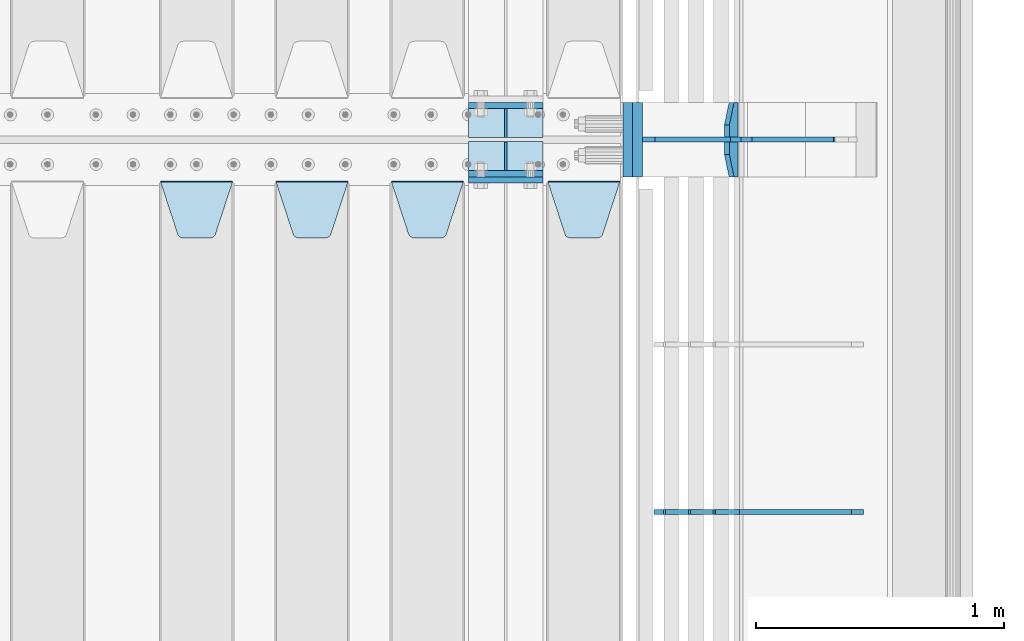
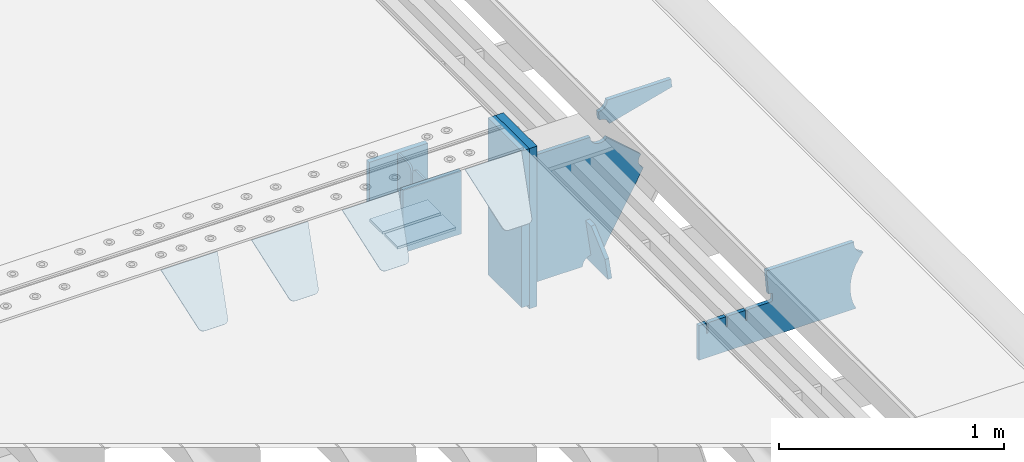
# One storey, part 225 of 247: 17 plates.
"""IFC2X3 building model written with IfcOpenShell, lengths in millimetres."""

from ifc_helpers import new_model, si_unit, frame, origin_with_axes, place, context, subcontext, project, spatial, faceted_brep, material, type_object, element, save


model = new_model("IFC2X3")

# Units and contexts
model_context = context("Model", 3, precision=1e-05, world=origin_with_axes())
body_context = subcontext(model_context, "Body", "Model", "MODEL_VIEW")
ifc_project = project(units=[si_unit("LENGTHUNIT", "METRE", prefix="MILLI"), si_unit("AREAUNIT", "SQUARE_METRE"), si_unit("VOLUMEUNIT", "CUBIC_METRE"), si_unit("MASSUNIT", "GRAM", prefix="KILO"), si_unit("TIMEUNIT", "SECOND"), si_unit("PLANEANGLEUNIT", "RADIAN"), si_unit("SOLIDANGLEUNIT", "STERADIAN"), si_unit("THERMODYNAMICTEMPERATUREUNIT", "DEGREE_CELSIUS"), si_unit("LUMINOUSINTENSITYUNIT", "LUMEN")], contexts=[model_context])

# Site, building, storey
site_placement = place(None, origin_with_axes())
site = spatial("IfcSite", under=ifc_project, at=site_placement, CompositionType="ELEMENT")
building_placement = place(site_placement, origin_with_axes())
building = spatial("IfcBuilding", under=site, at=building_placement, Name="Standard", CompositionType="ELEMENT")
storey_placement = place(building_placement, origin_with_axes())
storey = spatial("IfcBuildingStorey", under=building, at=storey_placement, Name="Undefined", CompositionType="ELEMENT", Elevation=0.0)

# Plates
ifc_material_1 = material(Name="STEEL/S355N")
plate_type_1 = type_object("IfcPlateType", PredefinedType="NOTDEFINED")
for number, where, z_axis, x_axis in (
    (1, (16195.0, 3137.49999999999, -339.999999999993), (0.0, 0.0, 1.0), (1.0, 0.0, 0.0)),
    (2, (16195.0, 2862.49999999999, -339.999999999993), (0.0, 0.0, 1.0), (1.0, 0.0, 0.0)),
):
    element("IfcPlate", number, at=place(storey_placement, frame(where, z_axis=z_axis, x_axis=x_axis)), inside=storey, type_object=plate_type_1, material=ifc_material_1, context=body_context, shape_type="Brep", body=[
        faceted_brep([(0.0, -12.5, 0.0), (0.0, -12.5, 310.0), (0.0, 12.5, 310.0), (0.0, 12.5, 0.0), (300.0, -12.5, 310.0), (300.0, 12.5, 310.0), (300.0, -12.5, 0.0), (300.0, 12.5, 0.0)], [[[0, 1, 2, 3]], [[1, 4, 5, 2]], [[4, 6, 7, 5]], [[6, 0, 3, 7]], [[5, 7, 3, 2]], [[6, 4, 1, 0]]]),
    ])
plate_1_placement = place(storey_placement, frame((16195.0, 2837.5, -340.000000000044), z_axis=(0.0, 0.0, 1.0), x_axis=(1.0, 0.0, 0.0)))
element("IfcPlate", 3, at=plate_1_placement, inside=storey, type_object=plate_type_1, material=ifc_material_1, context=body_context, shape_type="Brep", body=[
    faceted_brep([(0.0, -12.5, 0.0), (0.0, -12.5, 340.0), (0.0, 12.5, 340.0), (0.0, 12.5, 0.0), (300.0, -12.5, 340.0), (300.0, 12.5, 340.0), (300.0, -12.5, 0.0), (300.0, 12.5, 0.0)], [[[0, 1, 2, 3]], [[1, 4, 5, 2]], [[4, 6, 7, 5]], [[6, 0, 3, 7]], [[5, 7, 3, 2]], [[6, 4, 1, 0]]]),
])
plate_type_2 = type_object("IfcPlateType", PredefinedType="NOTDEFINED")
for number, where, z_axis, x_axis in (
    (4, (16195.0, 2991.99999999999, -342.999999999993), (0.0, -0.999999999999548, -9.5100000000016e-07), (1.0, 0.0, 0.0)),
    (5, (16195.0, 3007.99999999999, -342.999999999993), (0.0, 1.0, 0.0), (1.0, 0.0, 0.0)),
):
    element("IfcPlate", number, at=place(storey_placement, frame(where, z_axis=z_axis, x_axis=x_axis)), inside=storey, type_object=plate_type_2, material=ifc_material_1, context=body_context, shape_type="Brep", body=[
        faceted_brep([(0.0, -7.0, 0.0), (0.0, -7.0, 117.0), (0.0, 7.0, 117.0), (0.0, 7.0, 0.0), (300.0, -7.0, 117.0), (300.0, 7.0, 117.0), (300.0, -7.0, 0.0), (300.0, 7.0, 0.0)], [[[0, 1, 2, 3]], [[1, 4, 5, 2]], [[4, 6, 7, 5]], [[6, 0, 3, 7]], [[5, 7, 3, 2]], [[6, 4, 1, 0]]]),
    ])
plate_type_3 = type_object("IfcPlateType", PredefinedType="NOTDEFINED")
for number, where, z_axis, x_axis in (
    (6, (16345.0, 3007.99999999999, -29.999999999993), (0.0, 0.0, -1.0), (0.0, 1.0, 0.0)),
    (7, (16345.0, 2991.99999999999, -29.999999999993), (0.0, 0.0, -1.0), (0.0, -0.999999999999548, -9.5100000000016e-07)),
):
    element("IfcPlate", number, at=place(storey_placement, frame(where, z_axis=z_axis, x_axis=x_axis)), inside=storey, type_object=plate_type_3, material=ifc_material_1, context=body_context, shape_type="Brep", body=[
        faceted_brep([(0.0, -5.0, 30.0), (0.0, -5.0, 306.0), (0.0, 5.0, 306.0), (0.0, 5.0, 30.0), (117.0, -5.0, 306.0), (117.0, 5.0, 306.0), (117.0, -5.0, 0.0), (117.0, 5.0, 0.0), (30.0, -5.0, 0.0), (30.0, 5.0, 0.0), (24.7905546699922, -5.0, 0.455767409633758), (24.7905546699922, 5.0, 0.455767409633758), (19.73939570023, -5.0, 1.80922137642275), (19.73939570023, 5.0, 1.80922137642275), (15.0, -5.0, 4.01923788646684), (15.0, 5.0, 4.01923788646684), (10.716371709404, -5.0, 7.01866670643066), (10.716371709404, 5.0, 7.01866670643066), (7.01866670643085, -5.0, 10.7163717094038), (7.01866670643085, 5.0, 10.7163717094038), (4.01923788646673, -5.0, 15.0), (4.01923788646673, 5.0, 15.0), (1.80922137642256, -5.0, 19.7393957002299), (1.80922137642256, 5.0, 19.7393957002299), (0.455767409633609, -5.0, 24.7905546699921), (0.455767409633609, 5.0, 24.7905546699921)], [[[0, 1, 2, 3]], [[1, 4, 5, 2]], [[4, 6, 7, 5]], [[6, 8, 9, 7]], [[8, 10, 11, 9]], [[10, 12, 13, 11]], [[12, 14, 15, 13]], [[14, 16, 17, 15]], [[16, 18, 19, 17]], [[18, 20, 21, 19]], [[20, 22, 23, 21]], [[22, 24, 25, 23]], [[24, 0, 3, 25]], [[5, 7, 9, 11, 13, 15, 17, 19, 21, 23, 25, 3, 2]], [[24, 22, 20, 18, 16, 14, 12, 10, 8, 6, 4, 1, 0]]]),
    ])
plate_type_4 = type_object("IfcPlateType", PredefinedType="NOTDEFINED")
plate_2_placement = place(storey_placement, frame((16515.0, 2831.76776695594, -1.767766952965), z_axis=(0.0, -0.707106781186548, -0.707106781186547), x_axis=(1.0, 0.0, 0.0)))
element("IfcPlate", 8, at=plate_2_placement, inside=storey, type_object=plate_type_4, material=ifc_material_1, context=body_context, shape_type="Brep", body=[
    faceted_brep([(0.0, -2.49999999999909, 0.0), (69.345504679477, -2.5, 300.17173142483), (69.345504679477, 2.50000000000091, 300.171731424831), (0.0, 2.5, -9.09494701772928e-13), (70.9274061199576, -2.5, 304.897442415399), (70.9274061199576, 2.50000000000091, 304.8974424154), (73.3818627772307, -2.49999999999909, 309.234538108527), (73.3818627772307, 2.5, 309.234538108526), (76.6187032999551, -2.5, 313.023683126102), (76.6187032999551, 2.50000000000091, 313.023683126102), (80.5190132704993, -2.49999999999909, 316.125672595371), (80.5190132704993, 2.50000000000091, 316.125672595372), (84.9395038596849, -2.49999999999909, 318.426546230476), (84.9395038596849, 2.5, 318.426546230475), (89.7177759439219, -2.5, 319.841774983274), (89.7177759439219, 2.50000000000091, 319.841774983275), (94.678286292652, -2.5, 320.319366455077), (94.678286292652, 2.50000000000091, 320.319366455077), (195.321713707348, -2.5, 320.319366455077), (195.321713707348, 2.50000000000091, 320.319366455077), (200.282224056078, -2.5, 319.841774983274), (200.282224056078, 2.50000000000091, 319.841774983275), (205.060496140315, -2.5, 318.426546230475), (205.060496140315, 2.5, 318.426546230474), (209.480986729501, -2.49999999999818, 316.12567259537), (209.480986729501, 2.50000000000091, 316.12567259537), (213.381296700045, -2.5, 313.023683126101), (213.381296700045, 2.50000000000091, 313.023683126101), (216.618137222769, -2.5, 309.234538108525), (216.618137222769, 2.5, 309.234538108525), (219.072593880042, -2.49999999999909, 304.897442415398), (219.072593880042, 2.5, 304.897442415398), (220.654495320523, -2.5, 300.17173142483), (220.654495320523, 2.50000000000091, 300.171731424831), (290.0, -2.49999999999909, 0.0), (290.0, 2.5, -9.09494701772928e-13)], [[[0, 1, 2, 3]], [[1, 4, 5, 2]], [[4, 6, 7, 5]], [[6, 8, 9, 7]], [[8, 10, 11, 9]], [[10, 12, 13, 11]], [[12, 14, 15, 13]], [[14, 16, 17, 15]], [[16, 18, 19, 17]], [[18, 20, 21, 19]], [[20, 22, 23, 21]], [[22, 24, 25, 23]], [[24, 26, 27, 25]], [[26, 28, 29, 27]], [[28, 30, 31, 29]], [[30, 32, 33, 31]], [[32, 34, 35, 33]], [[34, 0, 3, 35]], [[5, 7, 9, 11, 13, 15, 17, 19, 21, 23, 25, 27, 29, 31, 33, 35, 3, 2]], [[34, 32, 30, 28, 26, 24, 22, 20, 18, 16, 14, 12, 10, 8, 6, 4, 1, 0]]]),
])
plate_3_placement = place(storey_placement, frame((15885.0, 2831.76776695594, -1.767766952965), z_axis=(0.0, -0.707106781186548, -0.707106781186547), x_axis=(1.0, 0.0, 0.0)))
element("IfcPlate", 9, at=plate_3_placement, inside=storey, type_object=plate_type_4, material=ifc_material_1, context=body_context, shape_type="Brep", body=[
    faceted_brep([(0.0, -2.49999999999909, 0.0), (69.345504679477, -2.5, 300.17173142483), (69.345504679477, 2.50000000000091, 300.171731424831), (0.0, 2.5, -9.09494701772928e-13), (70.9274061199576, -2.5, 304.897442415399), (70.9274061199576, 2.50000000000091, 304.8974424154), (73.3818627772307, -2.49999999999909, 309.234538108527), (73.3818627772307, 2.5, 309.234538108526), (76.6187032999551, -2.5, 313.023683126102), (76.6187032999551, 2.50000000000091, 313.023683126102), (80.5190132704993, -2.49999999999909, 316.125672595371), (80.5190132704993, 2.50000000000091, 316.125672595372), (84.9395038596849, -2.49999999999909, 318.426546230476), (84.9395038596849, 2.5, 318.426546230475), (89.7177759439219, -2.5, 319.841774983274), (89.7177759439219, 2.50000000000091, 319.841774983275), (94.678286292652, -2.5, 320.319366455077), (94.678286292652, 2.50000000000091, 320.319366455077), (195.321713707348, -2.5, 320.319366455077), (195.321713707348, 2.50000000000091, 320.319366455077), (200.282224056078, -2.5, 319.841774983274), (200.282224056078, 2.50000000000091, 319.841774983275), (205.060496140315, -2.5, 318.426546230475), (205.060496140315, 2.5, 318.426546230474), (209.480986729501, -2.49999999999818, 316.12567259537), (209.480986729501, 2.50000000000091, 316.12567259537), (213.381296700045, -2.5, 313.023683126101), (213.381296700045, 2.50000000000091, 313.023683126101), (216.618137222769, -2.5, 309.234538108525), (216.618137222769, 2.5, 309.234538108525), (219.072593880042, -2.49999999999909, 304.897442415398), (219.072593880042, 2.5, 304.897442415398), (220.654495320523, -2.5, 300.17173142483), (220.654495320523, 2.50000000000091, 300.171731424831), (290.0, -2.49999999999909, 0.0), (290.0, 2.5, -9.09494701772928e-13)], [[[0, 1, 2, 3]], [[1, 4, 5, 2]], [[4, 6, 7, 5]], [[6, 8, 9, 7]], [[8, 10, 11, 9]], [[10, 12, 13, 11]], [[12, 14, 15, 13]], [[14, 16, 17, 15]], [[16, 18, 19, 17]], [[18, 20, 21, 19]], [[20, 22, 23, 21]], [[22, 24, 25, 23]], [[24, 26, 27, 25]], [[26, 28, 29, 27]], [[28, 30, 31, 29]], [[30, 32, 33, 31]], [[32, 34, 35, 33]], [[34, 0, 3, 35]], [[5, 7, 9, 11, 13, 15, 17, 19, 21, 23, 25, 27, 29, 31, 33, 35, 3, 2]], [[34, 32, 30, 28, 26, 24, 22, 20, 18, 16, 14, 12, 10, 8, 6, 4, 1, 0]]]),
])
plate_4_placement = place(storey_placement, frame((15420.0, 2831.76776695594, -1.767766952965), z_axis=(0.0, -0.707106781186548, -0.707106781186547), x_axis=(1.0, 0.0, 0.0)))
element("IfcPlate", 10, at=plate_4_placement, inside=storey, type_object=plate_type_4, material=ifc_material_1, context=body_context, shape_type="Brep", body=[
    faceted_brep([(0.0, -2.49999999999909, 0.0), (69.345504679477, -2.5, 300.17173142483), (69.345504679477, 2.50000000000091, 300.171731424831), (0.0, 2.5, -9.09494701772928e-13), (70.9274061199576, -2.5, 304.897442415399), (70.9274061199576, 2.50000000000091, 304.8974424154), (73.3818627772307, -2.49999999999909, 309.234538108527), (73.3818627772307, 2.5, 309.234538108526), (76.6187032999551, -2.5, 313.023683126102), (76.6187032999551, 2.50000000000091, 313.023683126102), (80.5190132704993, -2.49999999999909, 316.125672595371), (80.5190132704993, 2.50000000000091, 316.125672595372), (84.9395038596849, -2.49999999999909, 318.426546230476), (84.9395038596849, 2.5, 318.426546230475), (89.7177759439219, -2.5, 319.841774983274), (89.7177759439219, 2.50000000000091, 319.841774983275), (94.678286292652, -2.5, 320.319366455077), (94.678286292652, 2.50000000000091, 320.319366455077), (195.321713707348, -2.5, 320.319366455077), (195.321713707348, 2.50000000000091, 320.319366455077), (200.282224056078, -2.5, 319.841774983274), (200.282224056078, 2.50000000000091, 319.841774983275), (205.060496140315, -2.5, 318.426546230475), (205.060496140315, 2.5, 318.426546230474), (209.480986729501, -2.49999999999818, 316.12567259537), (209.480986729501, 2.50000000000091, 316.12567259537), (213.381296700045, -2.5, 313.023683126101), (213.381296700045, 2.50000000000091, 313.023683126101), (216.618137222769, -2.5, 309.234538108525), (216.618137222769, 2.5, 309.234538108525), (219.072593880042, -2.49999999999909, 304.897442415398), (219.072593880042, 2.5, 304.897442415398), (220.654495320523, -2.5, 300.17173142483), (220.654495320523, 2.50000000000091, 300.171731424831), (290.0, -2.49999999999909, 0.0), (290.0, 2.5, -9.09494701772928e-13)], [[[0, 1, 2, 3]], [[1, 4, 5, 2]], [[4, 6, 7, 5]], [[6, 8, 9, 7]], [[8, 10, 11, 9]], [[10, 12, 13, 11]], [[12, 14, 15, 13]], [[14, 16, 17, 15]], [[16, 18, 19, 17]], [[18, 20, 21, 19]], [[20, 22, 23, 21]], [[22, 24, 25, 23]], [[24, 26, 27, 25]], [[26, 28, 29, 27]], [[28, 30, 31, 29]], [[30, 32, 33, 31]], [[32, 34, 35, 33]], [[34, 0, 3, 35]], [[5, 7, 9, 11, 13, 15, 17, 19, 21, 23, 25, 27, 29, 31, 33, 35, 3, 2]], [[34, 32, 30, 28, 26, 24, 22, 20, 18, 16, 14, 12, 10, 8, 6, 4, 1, 0]]]),
])
plate_5_placement = place(storey_placement, frame((14955.0, 2831.76776695594, -1.767766952965), z_axis=(0.0, -0.707106781186548, -0.707106781186547), x_axis=(1.0, 0.0, 0.0)))
element("IfcPlate", 11, at=plate_5_placement, inside=storey, type_object=plate_type_4, material=ifc_material_1, context=body_context, shape_type="Brep", body=[
    faceted_brep([(0.0, -2.49999999999909, 0.0), (69.345504679477, -2.5, 300.17173142483), (69.345504679477, 2.50000000000091, 300.171731424831), (0.0, 2.5, -9.09494701772928e-13), (70.9274061199576, -2.5, 304.897442415399), (70.9274061199576, 2.50000000000091, 304.8974424154), (73.3818627772307, -2.49999999999909, 309.234538108527), (73.3818627772307, 2.5, 309.234538108526), (76.6187032999551, -2.5, 313.023683126102), (76.6187032999551, 2.50000000000091, 313.023683126102), (80.5190132704993, -2.49999999999909, 316.125672595371), (80.5190132704993, 2.50000000000091, 316.125672595372), (84.9395038596849, -2.49999999999909, 318.426546230476), (84.9395038596849, 2.5, 318.426546230475), (89.7177759439219, -2.5, 319.841774983274), (89.7177759439219, 2.50000000000091, 319.841774983275), (94.678286292652, -2.5, 320.319366455077), (94.678286292652, 2.50000000000091, 320.319366455077), (195.321713707348, -2.5, 320.319366455077), (195.321713707348, 2.50000000000091, 320.319366455077), (200.282224056078, -2.5, 319.841774983274), (200.282224056078, 2.50000000000091, 319.841774983275), (205.060496140315, -2.5, 318.426546230475), (205.060496140315, 2.5, 318.426546230474), (209.480986729501, -2.49999999999818, 316.12567259537), (209.480986729501, 2.50000000000091, 316.12567259537), (213.381296700045, -2.5, 313.023683126101), (213.381296700045, 2.50000000000091, 313.023683126101), (216.618137222769, -2.5, 309.234538108525), (216.618137222769, 2.5, 309.234538108525), (219.072593880042, -2.49999999999909, 304.897442415398), (219.072593880042, 2.5, 304.897442415398), (220.654495320523, -2.5, 300.17173142483), (220.654495320523, 2.50000000000091, 300.171731424831), (290.0, -2.49999999999909, 0.0), (290.0, 2.5, -9.09494701772928e-13)], [[[0, 1, 2, 3]], [[1, 4, 5, 2]], [[4, 6, 7, 5]], [[6, 8, 9, 7]], [[8, 10, 11, 9]], [[10, 12, 13, 11]], [[12, 14, 15, 13]], [[14, 16, 17, 15]], [[16, 18, 19, 17]], [[18, 20, 21, 19]], [[20, 22, 23, 21]], [[22, 24, 25, 23]], [[24, 26, 27, 25]], [[26, 28, 29, 27]], [[28, 30, 31, 29]], [[30, 32, 33, 31]], [[32, 34, 35, 33]], [[34, 0, 3, 35]], [[5, 7, 9, 11, 13, 15, 17, 19, 21, 23, 25, 27, 29, 31, 33, 35, 3, 2]], [[34, 32, 30, 28, 26, 24, 22, 20, 18, 16, 14, 12, 10, 8, 6, 4, 1, 0]]]),
])
plate_type_5 = type_object("IfcPlateType", PredefinedType="NOTDEFINED")
plate_6_placement = place(storey_placement, frame((17271.0775331947, 3150.00000000169, -871.412303810021), z_axis=(0.0, -0.999999999999548, -9.5100000000016e-07), x_axis=(-0.137902988002446, 0.0, 0.990445741017648)))
element("IfcPlate", 12, at=plate_6_placement, inside=storey, type_object=plate_type_5, material=ifc_material_1, context=body_context, shape_type="Brep", body=[
    faceted_brep([(-5.6843418860808e-14, -9.99999999999989, 3.5527136788005e-15), (-1.98724592337385e-10, -10.0000000000036, 300.0), (-1.98724592337385e-10, 10.0, 300.0), (-5.6843418860808e-14, 10.0000000000001, 3.5527136788005e-15), (115.0, -10.0, 300.0), (115.0, 9.99999999999636, 300.0), (250.0, -10.0, 210.0), (250.0, 9.99999999999636, 210.0), (250.0, -10.0, 90.0), (250.0, 9.99999999999636, 90.0), (115.0, -10.0, -1.10503606265411e-10), (115.0, 9.99999999999636, -1.10503606265411e-10)], [[[0, 1, 2, 3]], [[1, 4, 5, 2]], [[4, 6, 7, 5]], [[6, 8, 9, 7]], [[8, 10, 11, 9]], [[10, 0, 3, 11]], [[5, 7, 9, 11, 3, 2]], [[10, 8, 6, 4, 1, 0]]]),
])
plate_type_6 = type_object("IfcPlateType", PredefinedType="NOTDEFINED")
plate_7_placement = place(storey_placement, frame((17299.9988298914, 3000.00000000007, -179.999999999866), z_axis=(0.0, 0.0, -1.0), x_axis=(-1.0, 0.0, 0.0)))
element("IfcPlate", 13, at=plate_7_placement, inside=storey, type_object=plate_type_6, material=ifc_material_1, context=body_context, shape_type="Brep", body=[
    faceted_brep([(46.0258547361445, 10.0, 641.078828352486), (73.3015011074785, 10.0, 445.179898435767), (73.3015011074785, -10.0, 445.179898435767), (46.0258547361445, -10.0, 641.078828352486), (53.4925862871278, 10.0, 442.421838675718), (53.4925862871278, -10.0, 442.421838675718), (25.7820501123933, 10.0, 641.444230671287), (25.7820501123933, -10.0, 641.444230671287), (54.6652503111618, 10.0, 642.447174185377), (54.6652503111618, -10.0, 642.447174185377), (68.6036632070354, -10.0, 649.549150281387), (68.6036632070354, 10.0, 649.549150281387), (79.6652503111618, -10.0, 660.610737385511), (79.6652503111618, 10.0, 660.610737385511), (86.7672264071698, -10.0, 674.549150281387), (86.7672264071698, 10.0, 674.549150281387), (89.2144005924129, -10.0, 690.0), (89.2144005924129, 10.0, 690.0), (353.0, -10.0, 690.0), (353.0, 10.0, 690.0), (355.447174185243, -10.0, 674.549150281253), (355.447174185243, 10.0, 674.549150281253), (362.549150281251, -10.0, 660.610737385376), (362.549150281251, 10.0, 660.610737385376), (373.610737385377, -10.0, 649.549150281253), (373.610737385377, 10.0, 649.549150281253), (387.549150281251, -10.0, 642.447174185242), (387.549150281251, 10.0, 642.447174185242), (403.0, -10.0, 640.0), (403.0, 10.0, 640.0), (403.0, -10.0, 50.0), (403.0, 10.0, 50.0), (387.549150281251, -10.0, 47.5528258147577), (387.549150281251, 10.0, 47.5528258147577), (373.610737385377, -10.0, 40.4508497187474), (373.610737385377, 10.0, 40.4508497187474), (362.549150281251, -10.0, 29.3892626146236), (362.549150281251, 10.0, 29.3892626146236), (355.447174185243, -10.0, 15.4508497187474), (355.447174185243, 10.0, 15.4508497187474), (353.0, -10.0, 0.0), (353.0, 10.0, 0.0), (50.0, -10.0, 0.0), (50.0, 10.0, 0.0), (47.0349915316328, -10.0, 16.9620037619133), (47.0349915316328, 10.0, 16.9620037619133), (38.4916171352343, -10.0, 31.9123081320451), (38.4916171352343, 10.0, 31.9123081320451), (25.3831239081519, -10.0, 43.0778019479116), (25.3831239081519, 10.0, 43.0778019479116), (9.26418358741648, -10.0, 49.1342538608113), (9.26418358741648, 10.0, 49.1342538608113), (-7.95349204488593, -10.0, 49.363366622344), (-7.95349204488593, 10.0, 49.363366622344), (-24.2278808265401, -10.0, 43.7379673813837), (-24.2278808265401, 10.0, 43.7379673813837), (-37.6288347353438, -10.0, 32.9252303934259), (-37.6288347353438, 10.0, 32.9252303934259), (-210.371165264656, -10.0, 184.074769606574), (-210.371165264656, 10.0, 184.074769606574), (-202.382363280569, -10.0, 196.529747922069), (-202.382363280569, 10.0, 196.529747922069), (-198.388707244045, -10.0, 210.777489969227), (-198.388707244045, 10.0, 210.777489969227), (-198.739957464426, -10.0, 225.570193077959), (-198.739957464426, 10.0, 225.570193077959), (-203.40535180681, -10.0, 239.612327446012), (-203.40535180681, 10.0, 239.612327446012), (-211.976299808361, -10.0, 251.674097313455), (-211.976299808361, 10.0, 251.674097313455), (-223.702166612962, -10.0, 260.699145216992), (-223.702166612962, 10.0, 260.699145216992), (-9.29783338703783, -10.0, 646.300854783008), (-9.29783338703783, 10.0, 646.300854783008), (6.98069453597782, -10.0, 640.647282345602), (6.98069453597782, 10.0, 640.647282345602), (24.2117663163663, -10.0, 640.855891896051), (24.2117663163663, 10.0, 640.855891896051)], [[[0, 1, 2, 3]], [[4, 5, 2, 1]], [[6, 7, 5, 4]], [[8, 9, 10, 11]], [[11, 10, 12, 13]], [[13, 12, 14, 15]], [[15, 14, 16, 17]], [[18, 19, 17, 16]], [[18, 20, 21, 19]], [[20, 22, 23, 21]], [[22, 24, 25, 23]], [[24, 26, 27, 25]], [[26, 28, 29, 27]], [[28, 30, 31, 29]], [[30, 32, 33, 31]], [[32, 34, 35, 33]], [[34, 36, 37, 35]], [[36, 38, 39, 37]], [[38, 40, 41, 39]], [[40, 42, 43, 41]], [[42, 44, 45, 43]], [[44, 46, 47, 45]], [[46, 48, 49, 47]], [[48, 50, 51, 49]], [[50, 52, 53, 51]], [[52, 54, 55, 53]], [[54, 56, 57, 55]], [[56, 58, 59, 57]], [[58, 60, 61, 59]], [[60, 62, 63, 61]], [[62, 64, 65, 63]], [[64, 66, 67, 65]], [[66, 68, 69, 67]], [[68, 70, 71, 69]], [[70, 72, 73, 71]], [[72, 74, 75, 73]], [[74, 76, 77, 75]], [[1, 0, 8, 11, 13, 15, 17, 19, 21, 23, 25, 27, 29, 31, 33, 35, 37, 39, 41, 43, 45, 47, 49, 51, 53, 55, 57, 59, 61, 63, 65, 67, 69, 71, 73, 75, 77, 6, 4]], [[9, 8, 0, 3]], [[76, 74, 72, 70, 68, 66, 64, 62, 60, 58, 56, 54, 52, 50, 48, 46, 44, 42, 40, 38, 36, 34, 32, 30, 28, 26, 24, 22, 20, 18, 16, 14, 12, 10, 9, 3, 2, 5, 7]], [[77, 76, 7, 6]]]),
])
plate_type_7 = type_object("IfcPlateType", PredefinedType="NOTDEFINED")
plate_8_placement = place(storey_placement, frame((17835.9988298906, 3000.0, -9.99999999999716), z_axis=(0.0, 0.0, -1.0), x_axis=(-1.0, 0.0, 0.0)))
element("IfcPlate", 14, at=plate_8_placement, inside=storey, type_object=plate_type_7, material=ifc_material_1, context=body_context, shape_type="Brep", body=[
    faceted_brep([(164.157641141064, -10.0, 44.1844865875018), (486.718340840864, -10.0, 131.004562768382), (486.718340840864, 10.0, 131.004562768382), (164.157641141064, 10.0, 44.1844865875018), (492.179177700767, -10.0, 118.185717565315), (492.179177700767, 10.0, 118.185717565315), (500.965368826703, -10.0, 107.371542744776), (500.965368826703, 10.0, 107.371542744776), (512.394601349042, -10.0, 99.4018391429503), (512.394601349042, 10.0, 99.4018391429503), (525.579310641864, -10.0, 94.8955133209048), (525.579310641864, 10.0, 94.8955133209048), (539.495606295339, -10.0, 94.2025148824028), (539.495606295339, 10.0, 94.2025148824028), (543.504393704661, -10.0, 49.7974851175972), (543.504393704661, 10.0, 49.7974851175972), (529.167086307516, -10.0, 46.3176139481669), (529.167086307516, 10.0, 46.3176139481669), (516.469507120331, -10.0, 38.8049999196639), (516.469507120331, 10.0, 38.8049999196639), (506.517198234546, -10.0, 27.9137449599276), (506.517198234546, 10.0, 27.9137449599276), (500.17667886756, -10.0, 14.592119649441), (500.17667886756, 10.0, 14.592119649441), (498.0, -10.0, 0.0), (498.0, 10.0, 0.0), (170.0, -10.0, 0.0), (170.0, 10.0, 0.0), (169.632873911985, -10.0, 11.1663820622718), (169.632873911985, 10.0, 11.1663820622718), (168.533081313406, -10.0, 22.2845350637931), (168.533081313406, 10.0, 22.2845350637931), (166.705372351957, -10.0, 33.3064382514178), (166.705372351957, 10.0, 33.3064382514178)], [[[0, 1, 2, 3]], [[1, 4, 5, 2]], [[4, 6, 7, 5]], [[6, 8, 9, 7]], [[8, 10, 11, 9]], [[10, 12, 13, 11]], [[12, 14, 15, 13]], [[14, 16, 17, 15]], [[16, 18, 19, 17]], [[18, 20, 21, 19]], [[20, 22, 23, 21]], [[22, 24, 25, 23]], [[24, 26, 27, 25]], [[26, 28, 29, 27]], [[28, 30, 31, 29]], [[30, 32, 33, 31]], [[32, 0, 3, 33]], [[5, 7, 9, 11, 13, 15, 17, 19, 21, 23, 25, 27, 29, 31, 33, 3, 2]], [[32, 30, 28, 26, 24, 22, 20, 18, 16, 14, 12, 10, 8, 6, 4, 1, 0]]]),
])
ifc_material_2 = material()
plate_type_8 = type_object("IfcPlateType", PredefinedType="NOTDEFINED")
plate_9_placement = place(storey_placement, frame((16876.9988298906, 3150.0, -889.999999999995), z_axis=(0.0, 0.0, 1.0), x_axis=(0.0, -0.999999999999548, -9.5100000000016e-07)))
element("IfcPlate", 15, at=plate_9_placement, inside=storey, type_object=plate_type_8, material=ifc_material_2, context=body_context, shape_type="Brep", body=[
    faceted_brep([(0.0, -20.0, 0.0), (0.0, -20.0, 870.0), (0.0, 20.0, 870.0), (0.0, 20.0, 0.0), (300.0, -20.0, 870.0), (300.0, 20.0, 870.0), (300.0, -20.0, -1.81898940354586e-12), (300.0, 20.0, -1.81898940354586e-12)], [[[0, 1, 2, 3]], [[1, 4, 5, 2]], [[4, 6, 7, 5]], [[6, 0, 3, 7]], [[5, 7, 3, 2]], [[6, 4, 1, 0]]]),
])
plate_10_placement = place(storey_placement, frame((16837.0, 3150.0, -870.0), z_axis=(0.0, 0.0, 1.0), x_axis=(0.0, -0.999999999999548, -9.5100000000016e-07)))
element("IfcPlate", 16, at=plate_10_placement, inside=storey, type_object=plate_type_8, material=ifc_material_2, context=body_context, shape_type="Brep", body=[
    faceted_brep([(0.0, -20.0, 0.0), (0.0, -20.0, 850.0), (0.0, 20.0, 850.0), (0.0, 20.0, 0.0), (300.0, -20.0, 850.0), (300.0, 20.0, 850.0), (300.0, -20.0, -1.81898940354586e-12), (300.0, 20.0, -1.81898940354586e-12)], [[[0, 1, 2, 3]], [[1, 4, 5, 2]], [[4, 6, 7, 5]], [[6, 0, 3, 7]], [[5, 7, 3, 2]], [[6, 4, 1, 0]]]),
])
plate_type_9 = type_object("IfcPlateType", PredefinedType="NOTDEFINED")
plate_11_placement = place(storey_placement, frame((17782.9182339676, 1499.99928283691, -374.002067436517), z_axis=(0.0, 0.0, 1.0), x_axis=(-1.0, 0.0, 0.0)))
element("IfcPlate", 17, at=plate_11_placement, inside=storey, type_object=plate_type_9, material=ifc_material_1, context=body_context, shape_type="Brep", body=[
    faceted_brep([(801.919404066546, -10.0, 188.0), (801.919404066546, 10.0, 188.0), (801.919404066546, 10.0, 132.002067436952), (801.919404066546, -10.0, 132.002067436952), (793.919404066546, 10.0, 132.002067436952), (793.919404066546, -10.0, 132.002067436952), (793.919404066546, 10.0, 180.002067436952), (793.919404066546, -10.0, 180.002067436952), (793.527856196906, 10.0, 182.474203391951), (793.527856196906, -10.0, 182.474203391951), (792.391540021545, 10.0, 184.704349455291), (792.391540021545, -10.0, 184.704349455291), (790.621686084887, 10.0, 186.474203391951), (790.621686084887, -10.0, 186.474203391951), (788.391540021545, 10.0, 187.610519567313), (788.391540021545, -10.0, 187.610519567313), (785.919404066546, -10.0, 188.002067436952), (785.919404066546, 10.0, 188.0), (841.0, -10.0, 188.0), (841.0, -10.0, 0.0), (841.0, 10.0, 0.0), (841.0, 10.0, 188.0), (33.3619566736015, -10.0, 0.0), (33.3619566736015, 10.0, 0.0), (36.2350612208174, -10.0, 4.68848050267013), (36.2350612208174, 10.0, 4.68848050267013), (51.4877592159428, -10.0, 41.5117508652784), (51.4877592159428, 10.0, 41.5117508652784), (60.792242588137, -10.0, 80.2677133162964), (60.792242588137, 10.0, 80.2677133162964), (63.9194040769726, -10.0, 120.002067436515), (63.9194040769726, 10.0, 120.002067436515), (60.792242588137, -10.0, 159.736421556734), (60.792242588137, 10.0, 159.736421556734), (51.4877592159428, -10.0, 198.492384007752), (51.4877592159428, 10.0, 198.492384007752), (36.2350612208174, -10.0, 235.31565437036), (36.2350612208174, 10.0, 235.31565437036), (15.4097206482074, -10.0, 269.299521518803), (15.4097206482074, 10.0, 269.299521518803), (-3.35474438098754, -10.0, 291.269887256574), (-3.35474438098754, 10.0, 291.269887256574), (-2.36881039375294, -10.0, 291.426043859339), (-2.36881039375294, 10.0, 291.426043859339), (17.1449676604716, -10.0, 301.368810393754), (17.1449676604716, 10.0, 301.368810393754), (32.6311896062471, -10.0, 316.855032339527), (32.6311896062471, 10.0, 316.855032339527), (42.573956140659, -10.0, 336.368810393754), (42.573956140659, 10.0, 336.368810393754), (46.0, -10.0, 358.0), (46.0, 10.0, 358.0), (45.0495205499137, -10.0, 364.001091067617), (45.0495205499137, 10.0, 364.001091067617), (495.040008544922, -10.0, 364.010009765625), (495.040008544922, 10.0, 364.010009765625), (483.600036621094, -10.0, 233.759994506836), (483.600036621094, 10.0, 233.759994506836), (472.0, -10.0, 233.759994506836), (472.0, 10.0, 233.759994506836), (468.909830056251, -10.0, 233.270559669787), (468.909830056251, 10.0, 233.270559669787), (466.122147477075, -10.0, 231.850164450585), (466.122147477075, 10.0, 231.850164450585), (463.909830056251, -10.0, 229.637847029761), (463.909830056251, 10.0, 229.637847029761), (462.489434837047, -10.0, 226.850164450585), (462.489434837047, 10.0, 226.850164450585), (462.0, -10.0, 223.759994506836), (462.0, 10.0, 223.759994506836), (462.0, -10.0, 198.0), (462.0, 10.0, 198.0), (462.489434837047, -10.0, 194.909830056251), (462.489434837047, 10.0, 194.909830056251), (463.909830056251, -10.0, 192.122147477075), (463.909830056251, 10.0, 192.122147477075), (466.122147477075, -10.0, 189.909830056251), (466.122147477075, 10.0, 189.909830056251), (468.909830056251, -10.0, 188.489434837048), (468.909830056251, 10.0, 188.489434837048), (472.0, -10.0, 188.0), (472.0, 10.0, 188.0), (585.919404066546, -10.0, 188.002067436952), (585.919404066546, 10.0, 188.0), (588.391540021545, -10.0, 187.610519567313), (588.391540021545, 10.0, 187.610519567313), (590.621686084887, -10.0, 186.474203391951), (590.621686084887, 10.0, 186.474203391951), (592.391540021545, -10.0, 184.704349455291), (592.391540021545, 10.0, 184.704349455291), (593.527856196906, -10.0, 182.474203391951), (593.527856196906, 10.0, 182.474203391951), (593.919404066546, -10.0, 180.002067436952), (593.919404066546, 10.0, 180.002067436952), (593.919404066546, -10.0, 132.002067436952), (593.919404066546, 10.0, 132.002067436952), (601.919404066546, -10.0, 132.002067436952), (601.919404066546, 10.0, 132.002067436952), (601.919404066546, -10.0, 188.0), (601.919404066546, 10.0, 188.0), (685.919404066546, -10.0, 188.002067436952), (685.919404066546, 10.0, 188.0), (688.391540021545, -10.0, 187.610519567313), (688.391540021545, 10.0, 187.610519567313), (690.621686084887, -10.0, 186.474203391951), (690.621686084887, 10.0, 186.474203391951), (692.391540021545, -10.0, 184.704349455291), (692.391540021545, 10.0, 184.704349455291), (693.527856196906, -10.0, 182.474203391951), (693.527856196906, 10.0, 182.474203391951), (693.919404066546, -10.0, 180.002067436952), (693.919404066546, 10.0, 180.002067436952), (693.919404066546, -10.0, 132.002067436952), (693.919404066546, 10.0, 132.002067436952), (701.919404066546, -10.0, 132.002067436952), (701.919404066546, 10.0, 132.002067436952), (701.919404066546, -10.0, 188.0), (701.919404066546, 10.0, 188.0)], [[[0, 1, 2, 3]], [[3, 2, 4, 5]], [[5, 4, 6, 7]], [[7, 6, 8, 9]], [[9, 8, 10, 11]], [[11, 10, 12, 13]], [[13, 12, 14, 15]], [[16, 15, 14, 17]], [[18, 19, 20, 21]], [[20, 19, 22, 23]], [[22, 24, 25, 23]], [[26, 27, 25, 24]], [[28, 29, 27, 26]], [[30, 31, 29, 28]], [[32, 33, 31, 30]], [[34, 35, 33, 32]], [[36, 37, 35, 34]], [[38, 39, 37, 36]], [[39, 38, 40, 41]], [[40, 42, 43, 41]], [[44, 45, 43, 42]], [[46, 47, 45, 44]], [[48, 49, 47, 46]], [[50, 51, 49, 48]], [[52, 53, 51, 50]], [[54, 55, 53, 52]], [[54, 56, 57, 55]], [[56, 58, 59, 57]], [[58, 60, 61, 59]], [[60, 62, 63, 61]], [[62, 64, 65, 63]], [[64, 66, 67, 65]], [[66, 68, 69, 67]], [[68, 70, 71, 69]], [[70, 72, 73, 71]], [[72, 74, 75, 73]], [[74, 76, 77, 75]], [[76, 78, 79, 77]], [[78, 80, 81, 79]], [[81, 80, 82, 83]], [[82, 84, 85, 83]], [[86, 87, 85, 84]], [[88, 89, 87, 86]], [[90, 91, 89, 88]], [[92, 93, 91, 90]], [[94, 95, 93, 92]], [[96, 97, 95, 94]], [[98, 99, 97, 96]], [[99, 98, 100, 101]], [[100, 102, 103, 101]], [[104, 105, 103, 102]], [[106, 107, 105, 104]], [[108, 109, 107, 106]], [[110, 111, 109, 108]], [[112, 113, 111, 110]], [[114, 115, 113, 112]], [[116, 117, 115, 114]], [[117, 116, 16, 17]], [[12, 10, 8, 6, 4, 2, 1, 21, 20, 23, 25, 27, 29, 31, 33, 35, 37, 39, 41, 43, 45, 47, 49, 51, 53, 55, 57, 59, 61, 63, 65, 67, 69, 71, 73, 75, 77, 79, 81, 83, 85, 87, 89, 91, 93, 95, 97, 99, 101, 103, 105, 107, 109, 111, 113, 115, 117, 17, 14]], [[18, 21, 1, 0]], [[116, 114, 112, 110, 108, 106, 104, 102, 100, 98, 96, 94, 92, 90, 88, 86, 84, 82, 80, 78, 76, 74, 72, 70, 68, 66, 64, 62, 60, 58, 56, 54, 52, 50, 48, 46, 44, 42, 40, 38, 36, 34, 32, 30, 28, 26, 24, 22, 19, 18, 0, 3, 5, 7, 9, 11, 13, 15, 16]]]),
])

save(model, "model.ifc")
